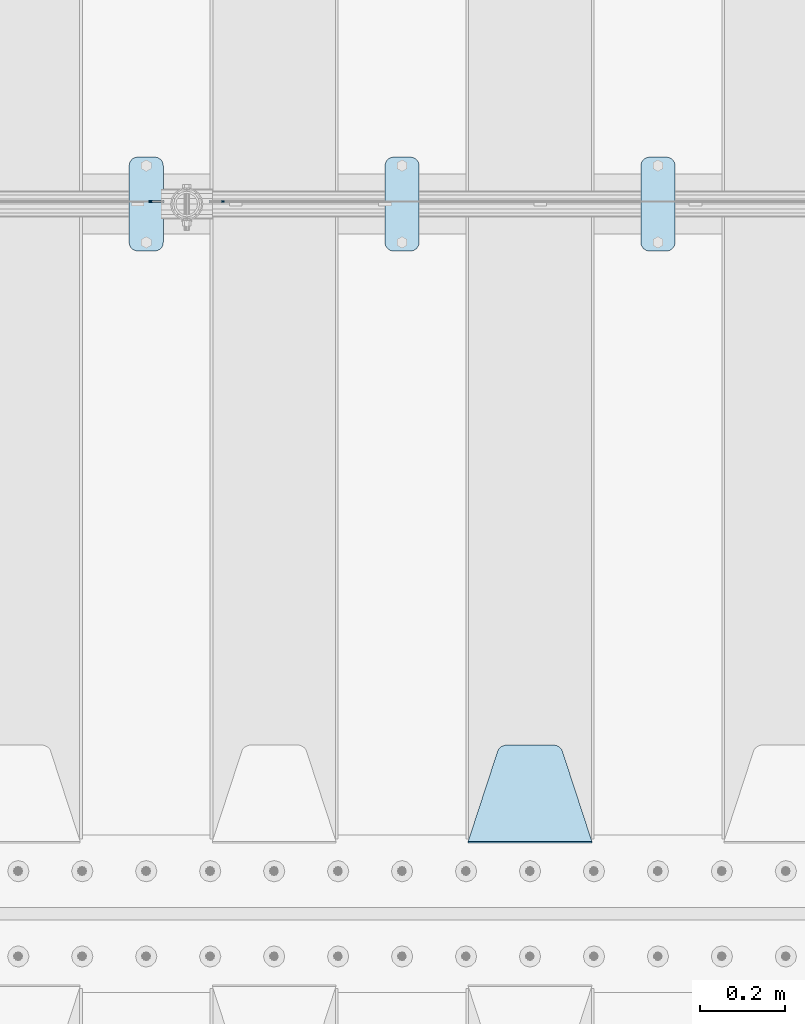
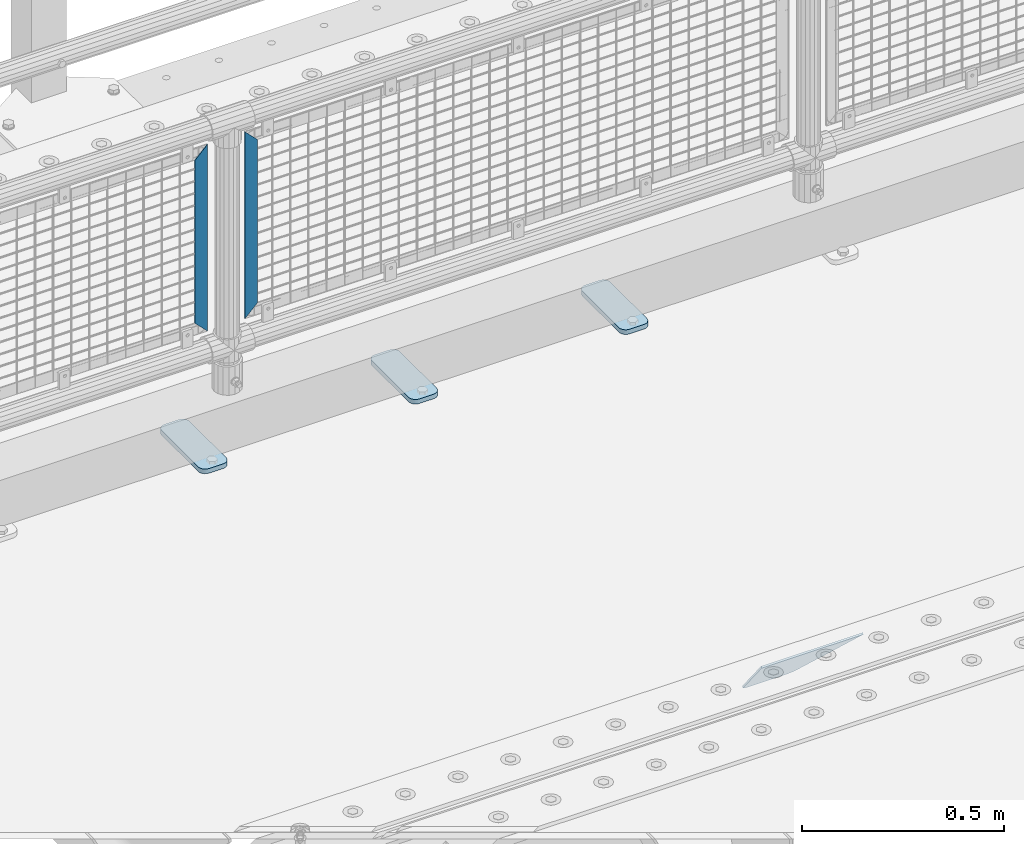
# One storey, part 162 of 193: 6 plates.
"""IFC2X3 building model written with IfcOpenShell, lengths in millimetres."""

from ifc_helpers import new_model, si_unit, frame, origin_with_axes, place, context, subcontext, project, spatial, faceted_brep, material, type_object, element, save


model = new_model("IFC2X3")

# Units and contexts
model_context = context("Model", 3, precision=1e-05, world=origin_with_axes())
body_context = subcontext(model_context, "Body", "Model", "MODEL_VIEW")
ifc_project = project(units=[si_unit("LENGTHUNIT", "METRE", prefix="MILLI"), si_unit("AREAUNIT", "SQUARE_METRE"), si_unit("VOLUMEUNIT", "CUBIC_METRE"), si_unit("MASSUNIT", "GRAM", prefix="KILO"), si_unit("TIMEUNIT", "SECOND"), si_unit("PLANEANGLEUNIT", "RADIAN"), si_unit("SOLIDANGLEUNIT", "STERADIAN"), si_unit("THERMODYNAMICTEMPERATUREUNIT", "DEGREE_CELSIUS"), si_unit("LUMINOUSINTENSITYUNIT", "LUMEN")], contexts=[model_context])

# Site, building, storey
site_placement = place(None, origin_with_axes())
site = spatial("IfcSite", under=ifc_project, at=site_placement, CompositionType="ELEMENT")
building_placement = place(site_placement, origin_with_axes())
building = spatial("IfcBuilding", under=site, at=building_placement, Name="Standard", CompositionType="ELEMENT")
storey_placement = place(building_placement, origin_with_axes())
storey = spatial("IfcBuildingStorey", under=building, at=storey_placement, Name="Undefined", CompositionType="ELEMENT", Elevation=0.0)

# Plates
ifc_material_1 = material(Name="STEEL/S355N")
plate_type_1 = type_object("IfcPlateType", PredefinedType="NOTDEFINED")
plate_1_placement = place(storey_placement, frame((-35905.0, 27168.232233047, -1.76776695296758), z_axis=(0.0, 0.707106781186547, -0.707106781186548), x_axis=(-1.0, 0.0, 0.0)))
element("IfcPlate", 1, at=plate_1_placement, inside=storey, type_object=plate_type_1, material=ifc_material_1, context=body_context, shape_type="Brep", body=[
    faceted_brep([(0.0, -2.5, 0.0), (69.345504679477, -2.50000000000364, 300.171731424831), (69.345504679477, 2.49999999999636, 300.171731424831), (0.0, 2.5, 0.0), (70.9274061199576, -2.50000000000364, 304.897442415397), (70.9274061199576, 2.49999999999636, 304.897442415397), (73.3818627772307, -2.50000000000364, 309.234538108529), (73.3818627772307, 2.49999999999636, 309.234538108529), (76.6187032999551, -2.50000000000728, 313.023683126103), (76.6187032999551, 2.49999999999636, 313.023683126103), (80.5190132704993, -2.50000000000364, 316.125672595372), (80.5190132704993, 2.49999999999636, 316.125672595368), (84.9395038596849, -2.50000000000364, 318.426546230472), (84.9395038596849, 2.49999999999636, 318.426546230476), (89.7177759439219, -2.50000000000364, 319.841774983273), (89.7177759439219, 2.49999999999636, 319.841774983277), (94.678286292652, -2.50000000000364, 320.319366455074), (94.678286292652, 2.49999999999636, 320.319366455074), (195.321713707348, -2.50000000000364, 320.319366455074), (195.321713707348, 2.49999999999636, 320.319366455074), (200.282224056078, -2.50000000000364, 319.841774983273), (200.282224056078, 2.49999999999636, 319.841774983277), (205.060496140315, -2.50000000000364, 318.426546230472), (205.060496140315, 2.49999999999636, 318.426546230472), (209.480986729501, -2.50000000000364, 316.125672595372), (209.480986729501, 2.49999999999636, 316.125672595368), (213.381296700045, -2.50000000000728, 313.023683126103), (213.381296700045, 2.49999999999272, 313.023683126103), (216.618137222769, -2.50000000000364, 309.234538108525), (216.618137222769, 2.49999999999636, 309.234538108522), (219.072593880042, -2.50000000000364, 304.897442415397), (219.072593880042, 2.49999999999636, 304.897442415397), (220.654495320523, -2.50000000000364, 300.171731424831), (220.654495320523, 2.49999999999636, 300.171731424831), (290.0, -2.50000000000364, 0.0), (290.0, 2.49999999999636, 0.0)], [[[0, 1, 2, 3]], [[1, 4, 5, 2]], [[4, 6, 7, 5]], [[6, 8, 9, 7]], [[8, 10, 11, 9]], [[10, 12, 13, 11]], [[12, 14, 15, 13]], [[14, 16, 17, 15]], [[16, 18, 19, 17]], [[18, 20, 21, 19]], [[20, 22, 23, 21]], [[22, 24, 25, 23]], [[24, 26, 27, 25]], [[26, 28, 29, 27]], [[28, 30, 31, 29]], [[30, 32, 33, 31]], [[32, 34, 35, 33]], [[34, 0, 3, 35]], [[5, 7, 9, 11, 13, 15, 17, 19, 21, 23, 25, 27, 29, 31, 33, 35, 3, 2]], [[34, 32, 30, 28, 26, 24, 22, 20, 18, 16, 14, 12, 10, 8, 6, 4, 1, 0]]]),
])
ifc_material_2 = material(Name="Misc_Undefined")
plate_type_2 = type_object("IfcPlateType", PredefinedType="NOTDEFINED")
plate_2_placement = place(storey_placement, frame((-36766.490286459, 28670.5, 879.519963133601), z_axis=(-0.707008801899319, 0.0, -0.707204746899291), x_axis=(-0.70720474689929, 0.0, 0.707008801899319)))
element("IfcPlate", 2, at=plate_2_placement, inside=storey, type_object=plate_type_2, material=ifc_material_2, context=body_context, shape_type="Brep", body=[
    faceted_brep([(0.0, -1.49999999999636, 3.63797880709171e-12), (-348.552185058594, -1.5, 348.655029296875), (-348.552185058594, 1.5, 348.655029296875), (0.0, 1.50000000000364, 7.27595761418343e-12), (-348.544891357422, -1.5, 398.152496337891), (-348.544891357422, 1.5, 398.152496337891), (49.50439453125, -1.5, 7.6397554948926e-11), (49.50439453125, 1.5, 7.6397554948926e-11)], [[[0, 1, 2, 3]], [[1, 4, 5, 2]], [[4, 6, 7, 5]], [[6, 0, 3, 7]], [[5, 7, 3, 2]], [[6, 4, 1, 0]]]),
])
plate_3_placement = place(storey_placement, frame((-36943.5003125164, 28670.5, 879.52), z_axis=(0.707103624179499, 0.0, -0.707109938179501), x_axis=(0.707109938179495, 0.0, 0.707103624179505)))
element("IfcPlate", 3, at=plate_3_placement, inside=storey, type_object=plate_type_2, material=ifc_material_2, context=body_context, shape_type="Brep", body=[
    faceted_brep([(0.0, -1.49999999999636, 3.63797880709171e-12), (-348.605163574215, -1.5, 348.602081298824), (-348.605163574215, 1.5, 348.602081298824), (0.0, 1.50000000000364, 7.27595761418343e-12), (-348.605163574215, -1.5, 398.099334716793), (-348.605163574215, 1.5, 398.099334716793), (49.4976959228552, -1.5, -1.01863406598568e-10), (49.4976959228552, 1.5, -1.01863406598568e-10)], [[[0, 1, 2, 3]], [[1, 4, 5, 2]], [[4, 6, 7, 5]], [[6, 0, 3, 7]], [[5, 7, 3, 2]], [[6, 4, 1, 0]]]),
])
ifc_material_3 = material(Name="STEEL/S355J2")
plate_type_3 = type_object("IfcPlateType", PredefinedType="NOTDEFINED")
plate_4_placement = place(storey_placement, frame((-35790.0, 28774.5, 21.0199999999977), z_axis=(1.0, 0.0, 0.0), x_axis=(0.0, -1.0, 0.0)))
element("IfcPlate", 4, at=plate_4_placement, inside=storey, type_object=plate_type_3, material=ifc_material_3, context=body_context, shape_type="Brep", body=[
    faceted_brep([(0.0, -7.0, 20.0), (0.0, -7.0, 60.0), (0.0, 7.0, 60.0), (0.0, 7.0, 20.0), (0.384294391937146, -7.0, 63.9018064403208), (0.384294391937146, 7.0, 63.9018064403208), (1.52240934977453, -7.0, 67.6536686473009), (1.52240934977453, 7.0, 67.6536686473009), (3.37060775395003, -7.0, 71.1114046603907), (3.37060775395003, 7.0, 71.1114046603907), (5.8578643762703, -7.0, 74.1421356237297), (5.8578643762703, 7.0, 74.1421356237297), (8.88859533960931, -7.0, 76.62939224605), (8.88859533960931, 7.0, 76.62939224605), (12.3463313526991, -7.0, 78.4775906502255), (12.3463313526991, 7.0, 78.4775906502255), (16.0981935596792, -7.0, 79.6157056080629), (16.0981935596792, 7.0, 79.6157056080629), (20.0, -7.0, 80.0), (20.0, 7.0, 80.0), (200.0, -7.0, 80.0), (200.0, 7.0, 80.0), (203.901806440321, -7.0, 79.6157056080629), (203.901806440321, 7.0, 79.6157056080629), (207.653668647301, -7.0, 78.4775906502255), (207.653668647301, 7.0, 78.4775906502255), (211.111404660391, -7.0, 76.62939224605), (211.111404660391, 7.0, 76.62939224605), (214.14213562373, -7.0, 74.1421356237297), (214.14213562373, 7.0, 74.1421356237297), (216.62939224605, -7.0, 71.1114046603907), (216.62939224605, 7.0, 71.1114046603907), (218.477590650225, -7.0, 67.6536686473009), (218.477590650225, 7.0, 67.6536686473009), (219.615705608063, -7.0, 63.9018064403208), (219.615705608063, 7.0, 63.9018064403208), (220.0, -7.0, 60.0), (220.0, 7.0, 60.0), (220.0, -7.0, 20.0), (220.0, 7.0, 20.0), (219.615705608063, -7.0, 16.0981935596792), (219.615705608063, 7.0, 16.0981935596792), (218.477590650225, -7.0, 12.3463313526991), (218.477590650225, 7.0, 12.3463313526991), (216.62939224605, -7.0, 8.88859533960931), (216.62939224605, 7.0, 8.88859533960931), (214.14213562373, -7.0, 5.8578643762703), (214.14213562373, 7.0, 5.8578643762703), (211.111404660391, -7.0, 3.37060775395003), (211.111404660391, 7.0, 3.37060775395003), (207.653668647301, -7.0, 1.52240934977453), (207.653668647301, 7.0, 1.52240934977453), (203.901806440321, -7.0, 0.384294391937146), (203.901806440321, 7.0, 0.384294391937146), (200.0, -7.0, 0.0), (200.0, 7.0, 0.0), (20.0, -7.0, 0.0), (20.0, 7.0, 0.0), (16.0981935596792, -7.0, 0.384294391937146), (16.0981935596792, 7.0, 0.384294391937146), (12.3463313526991, -7.0, 1.52240934977453), (12.3463313526991, 7.0, 1.52240934977453), (8.88859533960931, -7.0, 3.37060775395003), (8.88859533960931, 7.0, 3.37060775395003), (5.8578643762703, -7.0, 5.8578643762703), (5.8578643762703, 7.0, 5.8578643762703), (3.37060775395003, -7.0, 8.88859533960931), (3.37060775395003, 7.0, 8.88859533960931), (1.52240934977453, -7.0, 12.3463313526991), (1.52240934977453, 7.0, 12.3463313526991), (0.384294391937146, -7.0, 16.0981935596792), (0.384294391937146, 7.0, 16.0981935596792)], [[[0, 1, 2, 3]], [[1, 4, 5, 2]], [[4, 6, 7, 5]], [[6, 8, 9, 7]], [[8, 10, 11, 9]], [[10, 12, 13, 11]], [[12, 14, 15, 13]], [[14, 16, 17, 15]], [[16, 18, 19, 17]], [[18, 20, 21, 19]], [[20, 22, 23, 21]], [[22, 24, 25, 23]], [[24, 26, 27, 25]], [[26, 28, 29, 27]], [[28, 30, 31, 29]], [[30, 32, 33, 31]], [[32, 34, 35, 33]], [[34, 36, 37, 35]], [[36, 38, 39, 37]], [[38, 40, 41, 39]], [[40, 42, 43, 41]], [[42, 44, 45, 43]], [[44, 46, 47, 45]], [[46, 48, 49, 47]], [[48, 50, 51, 49]], [[50, 52, 53, 51]], [[52, 54, 55, 53]], [[54, 56, 57, 55]], [[56, 58, 59, 57]], [[58, 60, 61, 59]], [[60, 62, 63, 61]], [[62, 64, 65, 63]], [[64, 66, 67, 65]], [[66, 68, 69, 67]], [[68, 70, 71, 69]], [[70, 0, 3, 71]], [[5, 7, 9, 11, 13, 15, 17, 19, 21, 23, 25, 27, 29, 31, 33, 35, 37, 39, 41, 43, 45, 47, 49, 51, 53, 55, 57, 59, 61, 63, 65, 67, 69, 71, 3, 2]], [[70, 68, 66, 64, 62, 60, 58, 56, 54, 52, 50, 48, 46, 44, 42, 40, 38, 36, 34, 32, 30, 28, 26, 24, 22, 20, 18, 16, 14, 12, 10, 8, 6, 4, 1, 0]]]),
])
plate_5_placement = place(storey_placement, frame((-36390.0, 28774.5, 21.0199999999977), z_axis=(1.0, 0.0, 0.0), x_axis=(0.0, -1.0, 0.0)))
element("IfcPlate", 5, at=plate_5_placement, inside=storey, type_object=plate_type_3, material=ifc_material_3, context=body_context, shape_type="Brep", body=[
    faceted_brep([(0.0, -7.0, 20.0), (0.0, -7.0, 60.0), (0.0, 7.0, 60.0), (0.0, 7.0, 20.0), (0.384294391937146, -7.0, 63.9018064403208), (0.384294391937146, 7.0, 63.9018064403208), (1.52240934977453, -7.0, 67.6536686473009), (1.52240934977453, 7.0, 67.6536686473009), (3.37060775395003, -7.0, 71.1114046603907), (3.37060775395003, 7.0, 71.1114046603907), (5.8578643762703, -7.0, 74.1421356237297), (5.8578643762703, 7.0, 74.1421356237297), (8.88859533960931, -7.0, 76.62939224605), (8.88859533960931, 7.0, 76.62939224605), (12.3463313526991, -7.0, 78.4775906502255), (12.3463313526991, 7.0, 78.4775906502255), (16.0981935596792, -7.0, 79.6157056080629), (16.0981935596792, 7.0, 79.6157056080629), (20.0, -7.0, 80.0), (20.0, 7.0, 80.0), (200.0, -7.0, 80.0), (200.0, 7.0, 80.0), (203.901806440321, -7.0, 79.6157056080629), (203.901806440321, 7.0, 79.6157056080629), (207.653668647301, -7.0, 78.4775906502255), (207.653668647301, 7.0, 78.4775906502255), (211.111404660391, -7.0, 76.62939224605), (211.111404660391, 7.0, 76.62939224605), (214.14213562373, -7.0, 74.1421356237297), (214.14213562373, 7.0, 74.1421356237297), (216.62939224605, -7.0, 71.1114046603907), (216.62939224605, 7.0, 71.1114046603907), (218.477590650225, -7.0, 67.6536686473009), (218.477590650225, 7.0, 67.6536686473009), (219.615705608063, -7.0, 63.9018064403208), (219.615705608063, 7.0, 63.9018064403208), (220.0, -7.0, 60.0), (220.0, 7.0, 60.0), (220.0, -7.0, 20.0), (220.0, 7.0, 20.0), (219.615705608063, -7.0, 16.0981935596792), (219.615705608063, 7.0, 16.0981935596792), (218.477590650225, -7.0, 12.3463313526991), (218.477590650225, 7.0, 12.3463313526991), (216.62939224605, -7.0, 8.88859533960931), (216.62939224605, 7.0, 8.88859533960931), (214.14213562373, -7.0, 5.8578643762703), (214.14213562373, 7.0, 5.8578643762703), (211.111404660391, -7.0, 3.37060775395003), (211.111404660391, 7.0, 3.37060775395003), (207.653668647301, -7.0, 1.52240934977453), (207.653668647301, 7.0, 1.52240934977453), (203.901806440321, -7.0, 0.384294391937146), (203.901806440321, 7.0, 0.384294391937146), (200.0, -7.0, 0.0), (200.0, 7.0, 0.0), (20.0, -7.0, 0.0), (20.0, 7.0, 0.0), (16.0981935596792, -7.0, 0.384294391937146), (16.0981935596792, 7.0, 0.384294391937146), (12.3463313526991, -7.0, 1.52240934977453), (12.3463313526991, 7.0, 1.52240934977453), (8.88859533960931, -7.0, 3.37060775395003), (8.88859533960931, 7.0, 3.37060775395003), (5.8578643762703, -7.0, 5.8578643762703), (5.8578643762703, 7.0, 5.8578643762703), (3.37060775395003, -7.0, 8.88859533960931), (3.37060775395003, 7.0, 8.88859533960931), (1.52240934977453, -7.0, 12.3463313526991), (1.52240934977453, 7.0, 12.3463313526991), (0.384294391937146, -7.0, 16.0981935596792), (0.384294391937146, 7.0, 16.0981935596792)], [[[0, 1, 2, 3]], [[1, 4, 5, 2]], [[4, 6, 7, 5]], [[6, 8, 9, 7]], [[8, 10, 11, 9]], [[10, 12, 13, 11]], [[12, 14, 15, 13]], [[14, 16, 17, 15]], [[16, 18, 19, 17]], [[18, 20, 21, 19]], [[20, 22, 23, 21]], [[22, 24, 25, 23]], [[24, 26, 27, 25]], [[26, 28, 29, 27]], [[28, 30, 31, 29]], [[30, 32, 33, 31]], [[32, 34, 35, 33]], [[34, 36, 37, 35]], [[36, 38, 39, 37]], [[38, 40, 41, 39]], [[40, 42, 43, 41]], [[42, 44, 45, 43]], [[44, 46, 47, 45]], [[46, 48, 49, 47]], [[48, 50, 51, 49]], [[50, 52, 53, 51]], [[52, 54, 55, 53]], [[54, 56, 57, 55]], [[56, 58, 59, 57]], [[58, 60, 61, 59]], [[60, 62, 63, 61]], [[62, 64, 65, 63]], [[64, 66, 67, 65]], [[66, 68, 69, 67]], [[68, 70, 71, 69]], [[70, 0, 3, 71]], [[5, 7, 9, 11, 13, 15, 17, 19, 21, 23, 25, 27, 29, 31, 33, 35, 37, 39, 41, 43, 45, 47, 49, 51, 53, 55, 57, 59, 61, 63, 65, 67, 69, 71, 3, 2]], [[70, 68, 66, 64, 62, 60, 58, 56, 54, 52, 50, 48, 46, 44, 42, 40, 38, 36, 34, 32, 30, 28, 26, 24, 22, 20, 18, 16, 14, 12, 10, 8, 6, 4, 1, 0]]]),
])
plate_6_placement = place(storey_placement, frame((-36990.0, 28774.5, 21.0199999999977), z_axis=(1.0, 0.0, 0.0), x_axis=(0.0, -1.0, 0.0)))
element("IfcPlate", 6, at=plate_6_placement, inside=storey, type_object=plate_type_3, material=ifc_material_3, context=body_context, shape_type="Brep", body=[
    faceted_brep([(0.0, -7.0, 20.0), (0.0, -7.0, 60.0), (0.0, 7.0, 60.0), (0.0, 7.0, 20.0), (0.384294391937146, -7.0, 63.9018064403208), (0.384294391937146, 7.0, 63.9018064403208), (1.52240934977453, -7.0, 67.6536686473009), (1.52240934977453, 7.0, 67.6536686473009), (3.37060775395003, -7.0, 71.1114046603907), (3.37060775395003, 7.0, 71.1114046603907), (5.8578643762703, -7.0, 74.1421356237297), (5.8578643762703, 7.0, 74.1421356237297), (8.88859533960931, -7.0, 76.62939224605), (8.88859533960931, 7.0, 76.62939224605), (12.3463313526991, -7.0, 78.4775906502255), (12.3463313526991, 7.0, 78.4775906502255), (16.0981935596792, -7.0, 79.6157056080629), (16.0981935596792, 7.0, 79.6157056080629), (20.0, -7.0, 80.0), (20.0, 7.0, 80.0), (200.0, -7.0, 80.0), (200.0, 7.0, 80.0), (203.901806440321, -7.0, 79.6157056080629), (203.901806440321, 7.0, 79.6157056080629), (207.653668647301, -7.0, 78.4775906502255), (207.653668647301, 7.0, 78.4775906502255), (211.111404660391, -7.0, 76.62939224605), (211.111404660391, 7.0, 76.62939224605), (214.14213562373, -7.0, 74.1421356237297), (214.14213562373, 7.0, 74.1421356237297), (216.62939224605, -7.0, 71.1114046603907), (216.62939224605, 7.0, 71.1114046603907), (218.477590650225, -7.0, 67.6536686473009), (218.477590650225, 7.0, 67.6536686473009), (219.615705608063, -7.0, 63.9018064403208), (219.615705608063, 7.0, 63.9018064403208), (220.0, -7.0, 60.0), (220.0, 7.0, 60.0), (220.0, -7.0, 20.0), (220.0, 7.0, 20.0), (219.615705608063, -7.0, 16.0981935596792), (219.615705608063, 7.0, 16.0981935596792), (218.477590650225, -7.0, 12.3463313526991), (218.477590650225, 7.0, 12.3463313526991), (216.62939224605, -7.0, 8.88859533960931), (216.62939224605, 7.0, 8.88859533960931), (214.14213562373, -7.0, 5.8578643762703), (214.14213562373, 7.0, 5.8578643762703), (211.111404660391, -7.0, 3.37060775395003), (211.111404660391, 7.0, 3.37060775395003), (207.653668647301, -7.0, 1.52240934977453), (207.653668647301, 7.0, 1.52240934977453), (203.901806440321, -7.0, 0.384294391937146), (203.901806440321, 7.0, 0.384294391937146), (200.0, -7.0, 0.0), (200.0, 7.0, 0.0), (20.0, -7.0, 0.0), (20.0, 7.0, 0.0), (16.0981935596792, -7.0, 0.384294391937146), (16.0981935596792, 7.0, 0.384294391937146), (12.3463313526991, -7.0, 1.52240934977453), (12.3463313526991, 7.0, 1.52240934977453), (8.88859533960931, -7.0, 3.37060775395003), (8.88859533960931, 7.0, 3.37060775395003), (5.8578643762703, -7.0, 5.8578643762703), (5.8578643762703, 7.0, 5.8578643762703), (3.37060775395003, -7.0, 8.88859533960931), (3.37060775395003, 7.0, 8.88859533960931), (1.52240934977453, -7.0, 12.3463313526991), (1.52240934977453, 7.0, 12.3463313526991), (0.384294391937146, -7.0, 16.0981935596792), (0.384294391937146, 7.0, 16.0981935596792)], [[[0, 1, 2, 3]], [[1, 4, 5, 2]], [[4, 6, 7, 5]], [[6, 8, 9, 7]], [[8, 10, 11, 9]], [[10, 12, 13, 11]], [[12, 14, 15, 13]], [[14, 16, 17, 15]], [[16, 18, 19, 17]], [[18, 20, 21, 19]], [[20, 22, 23, 21]], [[22, 24, 25, 23]], [[24, 26, 27, 25]], [[26, 28, 29, 27]], [[28, 30, 31, 29]], [[30, 32, 33, 31]], [[32, 34, 35, 33]], [[34, 36, 37, 35]], [[36, 38, 39, 37]], [[38, 40, 41, 39]], [[40, 42, 43, 41]], [[42, 44, 45, 43]], [[44, 46, 47, 45]], [[46, 48, 49, 47]], [[48, 50, 51, 49]], [[50, 52, 53, 51]], [[52, 54, 55, 53]], [[54, 56, 57, 55]], [[56, 58, 59, 57]], [[58, 60, 61, 59]], [[60, 62, 63, 61]], [[62, 64, 65, 63]], [[64, 66, 67, 65]], [[66, 68, 69, 67]], [[68, 70, 71, 69]], [[70, 0, 3, 71]], [[5, 7, 9, 11, 13, 15, 17, 19, 21, 23, 25, 27, 29, 31, 33, 35, 37, 39, 41, 43, 45, 47, 49, 51, 53, 55, 57, 59, 61, 63, 65, 67, 69, 71, 3, 2]], [[70, 68, 66, 64, 62, 60, 58, 56, 54, 52, 50, 48, 46, 44, 42, 40, 38, 36, 34, 32, 30, 28, 26, 24, 22, 20, 18, 16, 14, 12, 10, 8, 6, 4, 1, 0]]]),
])

save(model, "model.ifc")
